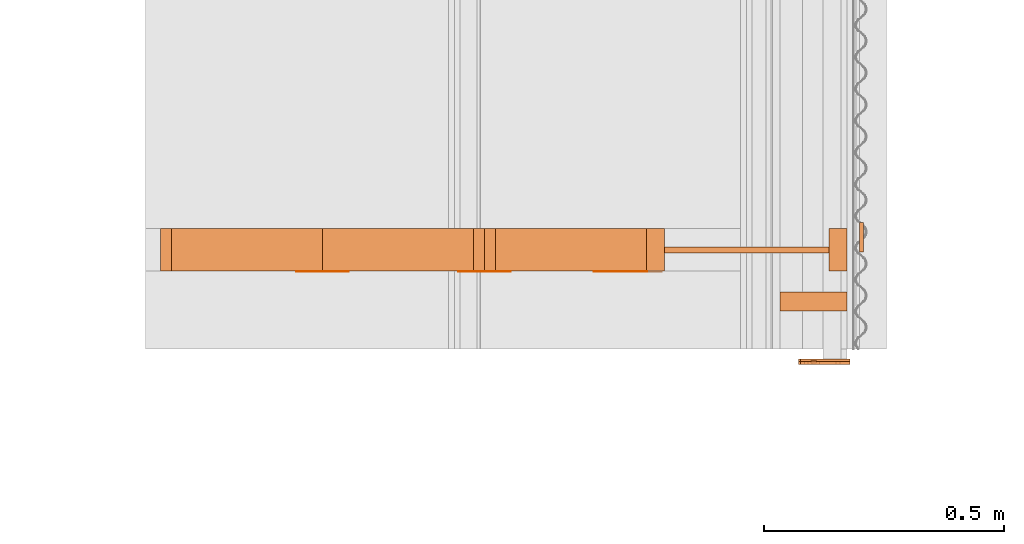
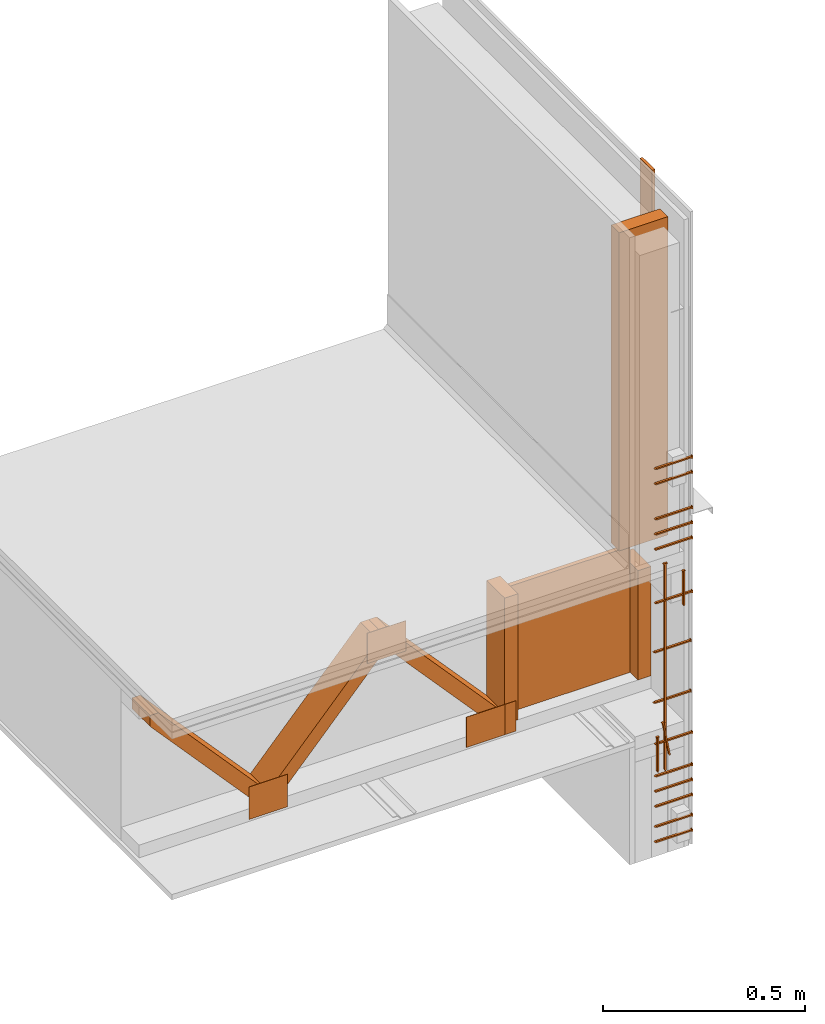
# One storey, part 8 of 22: 30 proxies.
"""IFC2X3 building model written with IfcOpenShell, lengths in feet."""

from ifc_helpers import new_model, entity, si_unit, converted_unit, frame, frame_2d, origin, origin_with_axes, place, context, subcontext, project, spatial, polyline, rectangle, outline, extrude, source, transform, mapped, material_list, type_object, type_shapes, element, save


model = new_model("IFC2X3")

# Units and contexts
model_context = context("Model", 3, precision=1e-05)
plan_context = context("Plan", 2, precision=1e-05, world=frame_2d((0.0, 0.0, 0.0), x_axis=(1.0, 0.0, 0.0)))
body_context_1 = subcontext(model_context, "Body", "Model", "MODEL_VIEW")
body_context_2 = subcontext(model_context, "Body", "Model", "MODEL_VIEW")
ifc_project = project(units=[converted_unit("VOLUMEUNIT", "cubic foot", entity("IfcReal", 0.0283168467116885), si_unit("VOLUMEUNIT", "CUBIC_METRE"), dimensions=[3, 0, 0, 0, 0, 0, 0]), converted_unit("AREAUNIT", "square foot", entity("IfcReal", 0.09290304), si_unit("AREAUNIT", "SQUARE_METRE"), dimensions=[2, 0, 0, 0, 0, 0, 0]), converted_unit("LENGTHUNIT", "foot", entity("IfcReal", 0.3048), si_unit("LENGTHUNIT", "METRE"), dimensions=[1, 0, 0, 0, 0, 0, 0])], contexts=[model_context, plan_context])

# Site, building, storey
site_placement = place(None, origin_with_axes())
site = spatial("IfcSite", under=ifc_project, at=site_placement, CompositionType="ELEMENT")
building_placement = place(site_placement, origin_with_axes())
building = spatial("IfcBuilding", under=site, at=building_placement, Name="Building", CompositionType="ELEMENT")
storey_placement = place(building_placement, origin_with_axes())
storey = spatial("IfcBuildingStorey", under=building, at=storey_placement, Name="Storey", CompositionType="ELEMENT")

# Proxies
ifc_material_list = material_list([])
building_element_proxy_type_1 = type_object("IfcBuildingElementProxyType", PredefinedType="NOTDEFINED", material=ifc_material_list)
shared_shape_1 = source(origin(), body_context_2, "Body", "SweptSolid", [
    extrude(outline(polyline([(0.678254804742618, 1.52290372278406e-09), (0.678378687755955, -0.00916582897667262), (0.687544515204868, -0.00904193908841474), (0.687048983151518, 0.0276213836931963), (0.677883155702606, 0.0274974915132983), (0.678007038715943, 0.0183316625366256), (-1.35638592202519, -0.0091658358515932), (-1.37459359613303, -0.0185794453686617), (-1.35613815599852, -0.0274974976243388), (0.678254804742618, 1.52290372278406e-09)])), frame((-0.0100000249649694, 9.22385177861048e-08, -0.678192814347625), z_axis=(-1.0, 0.0, 3.5932856690124e-08), x_axis=(3.60397933718559e-08, -0.0135152153670788, 0.999908626079559)), (-4.43113208348223e-08, -9.72645874952605e-09, -0.999999940395355), 0.0199999997321789),
])
type_shapes(building_element_proxy_type_1, [shared_shape_1])
proxy_1_placement = place(storey_placement, frame((1595.73852859457, 1.80479852859117, -59.9519724608093), z_axis=(-1.62920699153801e-07, -4.37113776285969e-08, 1.0), x_axis=(7.54979012640433e-08, 1.0, 4.37113882867379e-08)))
element("IfcBuildingElementProxy", 1, at=proxy_1_placement, inside=storey, type_object=building_element_proxy_type_1, context=body_context_2, shape_type="MappedRepresentation", body=[
    mapped(shared_shape_1, transform((0.0, 0.0, 0.0), x_axis=(1.0, 0.0, 0.0), y_axis=(0.0, 1.0, 0.0), z_axis=(0.0, 0.0, 1.0), scale=1.0)),
])
building_element_proxy_type_2 = type_object("IfcBuildingElementProxyType", PredefinedType="NOTDEFINED")
shared_shape_2 = source(origin_with_axes(), body_context_1, "Body", "SweptSolid", [
    extrude(outline(polyline([(0.111323627313291, 1.94594512519944e-12), (0.11174819796417, -0.00686187885598991), (0.11861007758404, -0.0064373005663101), (0.116911782758442, 0.0210102125660093), (0.110049903138572, 0.0205856342763295), (0.110474473789452, 0.0137237561842197), (-0.222222659531541, -0.00686187503658959), (-0.235521823676239, -0.0145729112358192), (-0.22137349378562, -0.0205856312208093), (0.111323627313291, 1.94594512519944e-12)])), frame((0.111111134212474, -9.54850080601499e-11, -8.48755740522435e-09), z_axis=(-7.22965936006403e-08, 7.6731799896184e-14, -1.0), x_axis=(-0.998091220855713, -0.0617568828165531, 7.2158591990501e-08)), (7.24534032769952e-08, -3.00251157270282e-10, -0.999999940395355), 0.0199999997321789),
])
type_shapes(building_element_proxy_type_2, [shared_shape_2])
for number, where, z_axis, x_axis in (
    (2, (1595.98082695107, 1.80479872414446, -60.8012745073774), (-3.25841369885893e-07, 1.0, 7.54979012640433e-08), (-1.0, -3.25841369885893e-07, -7.54979083694707e-08)),
    (3, (1595.98082695107, 1.80479852859117, -61.3012714335925), (-3.25841369885893e-07, 1.0, 7.54979012640433e-08), (-1.0, -3.25841369885893e-07, -7.54979083694707e-08)),
):
    element("IfcBuildingElementProxy", number, at=place(storey_placement, frame(where, z_axis=z_axis, x_axis=x_axis)), inside=storey, type_object=building_element_proxy_type_2, context=body_context_1, shape_type="MappedRepresentation", body=[
        mapped(shared_shape_2, transform((0.0, 0.0, 0.0), x_axis=(1.0, 0.0, 0.0), y_axis=(0.0, 1.0, 0.0), z_axis=(0.0, 0.0, 1.0), scale=1.0)),
    ])
building_element_proxy_type_3 = type_object("IfcBuildingElementProxyType", PredefinedType="NOTDEFINED")
shared_shape_3 = source(origin_with_axes(), body_context_1, "Body", "SweptSolid", [
    extrude(outline(polyline([(0.111323627313291, -4.3989495809459e-10), (0.11174819796417, -0.00686187809210984), (0.11861007758404, -0.00643729980243003), (0.11691175831428, 0.0210102125660093), (0.110049890916491, 0.0205856327485694), (0.110474473789452, 0.0137237546564596), (-0.222222659531541, -0.00686187580046965), (-0.235521848120402, -0.0145729081802989), (-0.22137349378562, -0.0205856312208093), (0.111323627313291, -4.3989495809459e-10)])), frame((0.111111134212474, 9.54850080601499e-11, -0.0200000086804153), z_axis=(-5.63213937709861e-08, 0.0, -1.0), x_axis=(-0.998091220855713, -0.0617568753659725, 6.86179575382084e-08)), (-2.94874541451051e-10, 4.76513584146687e-09, -0.999999940395355), 0.0199999997321788),
])
type_shapes(building_element_proxy_type_3, [shared_shape_3])
proxy_2_placement = place(storey_placement, frame((1595.66183415611, 1.80479852859117, -61.6394691267039), z_axis=(-1.62920684942947e-07, 1.0, -1.23001694617955e-14), x_axis=(7.54979012640433e-08, 0.0, -1.0)))
element("IfcBuildingElementProxy", 4, at=proxy_2_placement, inside=storey, type_object=building_element_proxy_type_3, context=body_context_1, shape_type="MappedRepresentation", body=[
    mapped(shared_shape_3, transform((0.0, 0.0, 0.0), x_axis=(1.0, 0.0, 0.0), y_axis=(0.0, 1.0, 0.0), z_axis=(0.0, 0.0, 1.0), scale=1.0)),
])
building_element_proxy_type_4 = type_object("IfcBuildingElementProxyType", PredefinedType="NOTDEFINED")
shared_shape_4 = source(origin_with_axes(), body_context_1, "Body", "SweptSolid", [
    extrude(outline(polyline([(-0.111111109768312, -0.0068750000238575), (0.222222243980786, -0.0068750000238575), (0.23597223180642, -2.15302076254909e-09), (0.222222268424948, 0.0068750023154977), (-0.111111121990393, 0.00687499925997744), (-0.111111109768312, 0.013750000047715), (-0.11798611590321, 0.013750000047715), (-0.11798611590321, -0.013750000047715), (-0.111111121990393, -0.0137500015754751), (-0.111111109768312, -0.0068750000238575)])), frame((0.111111109768312, 0.0, -0.020000005624895), z_axis=(-6.61350867403598e-08, -6.13854399169472e-14, -1.0), x_axis=(1.0, -2.29163998888282e-09, -6.87492018869307e-08)), (2.04888596323435e-14, 6.14665585682399e-14, -0.999999940395355), 0.0199999997321788),
])
type_shapes(building_element_proxy_type_4, [shared_shape_4])
proxy_3_placement = place(storey_placement, frame((1595.71409851234, 1.80479852859117, -61.5144714595765), z_axis=(-4.33873275085261e-08, 1.0, -7.5904100782509e-09), x_axis=(0.173648342490196, 5.90425555668794e-11, -0.984807729721069)))
element("IfcBuildingElementProxy", 5, at=proxy_3_placement, inside=storey, type_object=building_element_proxy_type_4, context=body_context_1, shape_type="MappedRepresentation", body=[
    mapped(shared_shape_4, transform((0.0, 0.0, 0.0), x_axis=(1.0, 0.0, 0.0), y_axis=(0.0, 1.0, 0.0), z_axis=(0.0, 0.0, 1.0), scale=1.0)),
])
building_element_proxy_type_5 = type_object("IfcBuildingElementProxyType", Name="PANEL EDGE REF SHEAR WALL SCHEDULE", PredefinedType="NOTDEFINED")
shared_shape_5 = source(origin_with_axes(), body_context_1, "Body", "SweptSolid", [
    extrude(outline(polyline([(0.23597223180642, 8.8975154745995e-18), (0.222222268424948, 0.00687500460713789), (-0.111111121990393, 0.00687499849609737), (-0.111111109768312, 0.0137499985199549), (-0.11798611590321, 0.0137499985199549), (-0.11798611590321, -0.0137500015754751), (-0.111111121990393, -0.0137500031032353), (-0.111111109768312, -0.00687500078773757), (0.222222243980786, -0.00687499773221731), (0.23597223180642, 8.8975154745995e-18)])), frame((0.111111109768312, -9.54850080601499e-11, -0.020000005624895), z_axis=(-6.14719368741135e-08, 0.0, -1.0), x_axis=(1.0, 7.23704740579478e-09, -6.47432187861341e-08)), (1.93505896527689e-14, 1.35692355582075e-22, -0.999999940395355), 0.0199999997321788),
])
type_shapes(building_element_proxy_type_5, [shared_shape_5])
for number, where, z_axis, x_axis in (
    (6, (1595.98082695107, 1.80479852859117, -59.118790263579), (-3.89414367418794e-07, 1.0, -1.62920684942947e-07), (-1.0, -3.89414367418794e-07, -7.5497894158616e-08)),
    (7, (1595.98082695107, 1.80479852859117, -58.9687930630261), (-3.89414367418794e-07, 1.0, -1.62920684942947e-07), (-1.0, -3.89414367418794e-07, -7.5497894158616e-08)),
    (8, (1595.98082695107, 1.80479852859117, -61.6987921747323), (-3.89414367418794e-07, 1.0, -1.62920684942947e-07), (-1.0, -3.89414367418794e-07, -7.5497894158616e-08)),
    (9, (1595.98082695107, 1.80479852859117, -62.6687928447573), (-3.89414367418794e-07, 1.0, -1.62920684942947e-07), (-1.0, -3.89414367418794e-07, -7.5497894158616e-08)),
    (10, (1595.98082695107, 1.80479852859117, -62.5187956442044), (-3.89414367418794e-07, 1.0, -1.62920684942947e-07), (-1.0, -3.89414367418794e-07, -7.5497894158616e-08)),
):
    element("IfcBuildingElementProxy", number, at=place(storey_placement, frame(where, z_axis=z_axis, x_axis=x_axis)), inside=storey, type_object=building_element_proxy_type_5, context=body_context_1, shape_type="MappedRepresentation", body=[
        mapped(shared_shape_5, transform((0.0, 0.0, 0.0), x_axis=(1.0, 0.0, 0.0), y_axis=(0.0, 1.0, 0.0), z_axis=(0.0, 0.0, 1.0), scale=1.0)),
    ])
building_element_proxy_type_6 = type_object("IfcBuildingElementProxyType", PredefinedType="NOTDEFINED")
shared_shape_6 = source(origin_with_axes(), body_context_1, "Body", "SweptSolid", [
    extrude(outline(polyline([(0.23597223180642, 8.8975154745995e-18), (0.222222268424948, 0.00687500460713789), (-0.111111121990393, 0.00687499849609737), (-0.111111109768312, 0.0137499985199549), (-0.11798611590321, 0.0137499985199549), (-0.11798611590321, -0.0137500015754751), (-0.111111121990393, -0.0137500031032353), (-0.111111109768312, -0.00687500078773757), (0.222222243980786, -0.00687499773221731), (0.23597223180642, 8.8975154745995e-18)])), frame((0.111111109768312, -9.54850080601499e-11, -0.020000005624895), z_axis=(-6.14719368741135e-08, 0.0, -1.0), x_axis=(1.0, 7.23704740579478e-09, -6.47432187861341e-08)), (1.93505896527689e-14, 1.35692355582075e-22, -0.999999940395355), 0.0199999997321788),
])
type_shapes(building_element_proxy_type_6, [shared_shape_6])
proxy_4_placement = place(storey_placement, frame((1595.98082695107, 1.80479852859117, -60.3012775811623), z_axis=(-3.89414367418794e-07, 1.0, -1.62920684942947e-07), x_axis=(-1.0, -3.89414367418794e-07, -7.54978870531886e-08)))
element("IfcBuildingElementProxy", 11, at=proxy_4_placement, inside=storey, type_object=building_element_proxy_type_6, context=body_context_1, shape_type="MappedRepresentation", body=[
    mapped(shared_shape_6, transform((0.0, 0.0, 0.0), x_axis=(1.0, 0.0, 0.0), y_axis=(0.0, 1.0, 0.0), z_axis=(0.0, 0.0, 1.0), scale=1.0)),
])
building_element_proxy_type_7 = type_object("IfcBuildingElementProxyType", PredefinedType="NOTDEFINED")
shared_shape_7 = source(origin_with_axes(), body_context_1, "Body", "SweptSolid", [
    extrude(outline(polyline([(-0.222222268424948, -0.00687500078773757), (0.111111121990393, -0.00687500078773757), (0.111111109768312, -0.0137500015754751), (0.11798611590321, -0.0137500015754751), (0.11798611590321, 0.0137499985199549), (0.111111121990393, 0.013750000047715), (0.111111109768312, 0.00687499849609737), (-0.222222243980786, 0.00687500155161763), (-0.23597223180642, 4.23241967865452e-09), (-0.222222268424948, -0.00687500078773757)])), frame((0.111111109768312, 8.3654694792787e-11, -0.020000005624895), z_axis=(-6.03443481850263e-08, -6.13854466932108e-14, -1.0), x_axis=(-1.0, 1.14581997223695e-08, 5.95826392668641e-08)), (-1.82123196731943e-14, -6.14665585682399e-14, -0.999999940395355), 0.0199999997321788),
])
type_shapes(building_element_proxy_type_7, [shared_shape_7])
for number, where, z_axis, x_axis in (
    (12, (1595.98082695107, 1.80479852859117, -59.7687843903469), (-3.89414367418794e-07, 1.0, -1.62920684942947e-07), (-1.0, -3.89414367418794e-07, -7.5497894158616e-08)),
    (13, (1595.98082695107, 1.80479852859117, -59.618787189794), (-3.89414367418794e-07, 1.0, -1.62920684942947e-07), (-1.0, -3.89414367418794e-07, -7.5497894158616e-08)),
    (14, (1595.98082695107, 1.80479852859117, -59.4687899892412), (-3.89414367418794e-07, 1.0, -1.62920684942947e-07), (-1.0, -3.89414367418794e-07, -7.5497894158616e-08)),
    (15, (1595.98082695107, 1.80479852859117, -62.3187868613896), (-3.89414367418794e-07, 1.0, -1.62920684942947e-07), (-1.0, -3.89414367418794e-07, -7.5497894158616e-08)),
    (16, (1595.98082695107, 1.80479852859117, -62.1687896608368), (-3.89414367418794e-07, 1.0, -1.62920684942947e-07), (-1.0, -3.89414367418794e-07, -7.5497894158616e-08)),
    (17, (1595.98082695107, 1.80479852859117, -62.0187924602839), (-3.89414367418794e-07, 1.0, -1.62920684942947e-07), (-1.0, -3.89414367418794e-07, -7.5497894158616e-08)),
):
    element("IfcBuildingElementProxy", number, at=place(storey_placement, frame(where, z_axis=z_axis, x_axis=x_axis)), inside=storey, type_object=building_element_proxy_type_7, context=body_context_1, shape_type="MappedRepresentation", body=[
        mapped(shared_shape_7, transform((0.0, 0.0, 0.0), x_axis=(1.0, 0.0, 0.0), y_axis=(0.0, 1.0, 0.0), z_axis=(0.0, 0.0, 1.0), scale=1.0)),
    ])
building_element_proxy_type_8 = type_object("IfcBuildingElementProxyType", Name="SUBFLOOR TO RIBBON BOARD", PredefinedType="NOTDEFINED")
shared_shape_8 = source(origin_with_axes(), body_context_1, "Body", "SweptSolid", [
    extrude(outline(polyline([(-0.222222268424948, -0.00687499849609737), (0.111111109768312, -0.00687499849609737), (0.111111109768312, -0.013750000047715), (0.117986103681129, -0.013750000047715), (0.117986103681129, 0.0137500031032353), (0.111111109768312, 0.0137500015754751), (0.111111109768312, 0.00687499925997744), (-0.222222243980786, 0.00687499925997744), (-0.23597223180642, -3.87233552310243e-09), (-0.222222268424948, -0.00687499849609737)])), frame((0.111111109768312, 1.11521265392398e-09, -0.020000005624895), z_axis=(-7.04017537600521e-08, -6.90586436234882e-14, -1.0), x_axis=(-1.0, -6.87492018869307e-09, 6.87492018869307e-08)), (-1.70740496936196e-14, 3.81939351257188e-08, -1.0), 0.0200000007111508),
])
type_shapes(building_element_proxy_type_8, [shared_shape_8])
proxy_5_placement = place(storey_placement, frame((1595.90643534823, 1.80479833303787, -60.0745671690293), z_axis=(-1.62920684942947e-07, 1.0, -1.23001694617955e-14), x_axis=(7.54979012640433e-08, 0.0, -1.0)))
element("IfcBuildingElementProxy", 18, at=proxy_5_placement, inside=storey, type_object=building_element_proxy_type_8, context=body_context_1, shape_type="MappedRepresentation", body=[
    mapped(shared_shape_8, transform((0.0, 0.0, 0.0), x_axis=(1.0, 0.0, 0.0), y_axis=(0.0, 1.0, 0.0), z_axis=(0.0, 0.0, 1.0), scale=1.0)),
])
proxy_6_placement = place(storey_placement, frame((1595.22189242946, -0.783451722832177, -57.8829747798249), z_axis=(0.0, 0.0, 1.0), x_axis=(1.0, 0.0, 0.0)))
element("IfcBuildingElementProxy", 19, at=proxy_6_placement, inside=storey, Name="Plane", context=body_context_1, shape_type="SweptSolid", body=[
    extrude(rectangle(XDim=0.129999920355563, YDim=0.458287070881728, at=frame_2d((0.0, 0.0, 0.0))), frame((0.516643596133535, 2.99930689841744, -2.07206552110006), z_axis=(0.0, 0.0, -1.0), x_axis=(0.0, 1.0, 0.0)), (0.0, 0.0, -1.0), 3.1556764266711),
])
proxy_7_placement = place(storey_placement, frame((1596.05311596487, 4.62063145762666, -59.6164906118798), z_axis=(0.0, 0.0, 1.0), x_axis=(1.0, 0.0, 0.0)))
element("IfcBuildingElementProxy", 20, at=proxy_7_placement, inside=storey, Name="Plane", context=body_context_1, shape_type="SweptSolid", body=[
    extrude(rectangle(XDim=0.20000017706096, YDim=0.0259999838903791, at=frame_2d((0.0, 0.0, 0.0))), frame((0.0130391027045062, -1.96291666644139, -1.5644263720575e-06), z_axis=(0.0, 0.0, -1.0), x_axis=(0.0, 0.999999940395355, 0.0)), (0.0, 0.0, -0.999999940395355), 2.99999996554402),
])
proxy_8_placement = place(storey_placement, frame((1592.06991120586, 2.42488121423196, -61.9758708583401), z_axis=(0.0, 0.0, 1.0), x_axis=(1.0, 0.0, 0.0)))
element("IfcBuildingElementProxy", 21, at=proxy_8_placement, inside=storey, Name="Generic Models 855:Generic Models 1", context=body_context_1, shape_type="SweptSolid", body=[
    extrude(outline(polyline([(-0.784177421115515, -0.0648421487157426), (0.754565518750293, -0.0648422464923909), (0.835367211988905, 0.00826408231039373), (0.784177372227191, 0.0648422220482288), (-0.754565469861969, 0.0648421487157426), (-0.835367211988905, -0.00826398453374547), (-0.784177421115515, -0.0648421487157426)])), frame((0.859770405636685, 2.21605038198473e-07, 1.08333436522897), z_axis=(-5.63129143316132e-09, -1.0, -3.61698013762179e-08), x_axis=(-0.670913577079773, 3.05994660720899e-08, -0.741535544395447)), (3.05994909410856e-08, 2.00910239556151e-08, -1.0), 0.291666664589754),
])
for number, where, z_axis, x_axis, name in (
    (22, (1592.06991120586, 2.42488121423196, -61.9758708583401), (0.0, 0.0, 1.0), (1.0, 0.0, 0.0), "Generic Models 855:Generic Models 1"),
    (23, (1589.85258087398, 2.42488121423196, -61.9758708583401), (0.0, 0.0, 1.0), (1.0, 0.0, 0.0), "Generic Models 855:Generic Models 1"),
):
    element("IfcBuildingElementProxy", number, at=place(storey_placement, frame(where, z_axis=z_axis, x_axis=x_axis)), inside=storey, Name=name, context=body_context_1, shape_type="SweptSolid", body=[
        extrude(outline(polyline([(-0.784177225562218, -0.0648422709365529), (0.75456571430359, -0.0648423442690391), (0.835367309765553, 0.00826388675709722), (0.784177470003839, 0.0648420509390944), (-0.754565274308673, 0.0648421731599047), (-0.835367016435608, -0.00826420453120404), (-0.784177225562218, -0.0648422709365529)])), frame((1.96849052205173, 0.291666910638959, 1.08333377856908), z_axis=(0.0, 1.0, 0.0), x_axis=(-0.670913577079773, 0.0, 0.741535604000092)), (0.0, 1.67617116630936e-07, -1.0), 0.291666664589758),
    ])
proxy_9_placement = place(storey_placement, frame((1590.96124603992, 2.42488121423196, -61.8508731912127), z_axis=(0.0, 0.0, 1.0), x_axis=(1.0, 0.0, 0.0)))
element("IfcBuildingElementProxy", 24, at=proxy_9_placement, inside=storey, Name="Generic Models 855:Generic Models 1", context=body_context_1, shape_type="SweptSolid", body=[
    extrude(rectangle(XDim=0.124999233345449, YDim=0.291669311091376, at=frame_2d((0.0, 0.0, 0.0))), frame((3.69392433191535, 0.145834848636717, 0.333333109307477), z_axis=(-1.56443593368749e-06, 0.0, -1.0), x_axis=(0.999999940395355, 0.0, -1.56443593368749e-06)), (-7.30079079858115e-07, 0.0, -1.0), 1.25000238621637),
])
proxy_10_placement = place(storey_placement, frame((1592.21128528825, 2.42488121423196, -61.8508731912127), z_axis=(0.0, 0.0, 1.0), x_axis=(1.0, 0.0, 0.0)))
element("IfcBuildingElementProxy", 25, at=proxy_10_placement, inside=storey, Name="Generic Models 855:Generic Models 1", context=body_context_1, shape_type="SweptSolid", body=[
    extrude(rectangle(XDim=0.124999233345449, YDim=0.291669311091376, at=frame_2d((0.0, 0.0, 0.0))), frame((3.69392433191535, 0.145834848636717, 0.333333109307477), z_axis=(-1.56443593368749e-06, 0.0, -1.0), x_axis=(-0.999999940395355, 0.0, 1.56443593368749e-06)), (6.02304339736293e-07, 0.0, -0.999999940395355), 1.08399728678613),
])
proxy_11_placement = place(storey_placement, frame((1596.85830744546, 2.54988416129836, -59.5704714457194), z_axis=(0.0, 0.0, 1.0), x_axis=(-1.62920684942947e-07, 1.0, 0.0)))
element("IfcBuildingElementProxy", 26, at=proxy_11_placement, inside=storey, Name="Plane", context=body_context_1, shape_type="SweptSolid", body=[
    extrude(rectangle(XDim=0.0416666640300221, YDim=1.12508459659183, at=frame_2d((0.0, 0.0, 0.0))), frame((0.0208332826654742, 1.57809906744269, -1.94706785397267), z_axis=(0.0, 0.0, -1.0), x_axis=(1.0, 0.0, 0.0)), (-1.46664405065167e-08, 0.0, -0.999999940395355), 1.25000482420942),
])
proxy_12_placement = place(storey_placement, frame((1592.11857112374, 2.42211120178693, -61.6217035008228), z_axis=(0.0, 0.0, 1.0), x_axis=(1.0, 0.0, 0.0)))
element("IfcBuildingElementProxy", 27, at=proxy_12_placement, inside=storey, Name="Generic Models 852:Generic Models 1", context=body_context_1, shape_type="SweptSolid", body=[
    extrude(rectangle(XDim=0.360929982303518, YDim=0.00277022707595213, at=frame_2d((0.0, 0.0, 0.0))), frame((2.39778886942726, 0.00138511354766121, 0.0), z_axis=(0.0, 0.0, -1.0), x_axis=(1.0, 0.0, 0.0)), (0.0, 0.0, -1.0), 0.301264184929359),
])
proxy_13_placement = place(storey_placement, frame((1592.19496519234, 2.42211120178693, -61.9550389567698), z_axis=(0.0, 0.0, 1.0), x_axis=(1.0, 0.0, 0.0)))
element("IfcBuildingElementProxy", 28, at=proxy_13_placement, inside=storey, Name="Generic Models 852:Generic Models 1", context=body_context_1, shape_type="SweptSolid", body=[
    extrude(rectangle(XDim=0.360930176725411, YDim=0.00277022707595213, at=frame_2d((0.0, 0.0, 0.0))), frame((1.28912702789457, 0.00138511354766121, 1.4904025071875), z_axis=(0.0, 0.0, -1.0), x_axis=(1.0, 0.0, 0.0)), (0.0, 0.0, -1.0), 0.301264218204712),
])
proxy_14_placement = place(storey_placement, frame((1592.19496519234, 2.42211120178693, -61.6217035008228), z_axis=(0.0, 0.0, 1.0), x_axis=(1.0, 0.0, 0.0)))
element("IfcBuildingElementProxy", 29, at=proxy_14_placement, inside=storey, Name="Generic Models 852:Generic Models 1", context=body_context_1, shape_type="SweptSolid", body=[
    extrude(rectangle(XDim=0.360930148950862, YDim=0.00277022707595213, at=frame_2d((0.0, 0.0, 0.0))), frame((0.180465076363149, 0.00138511354766121, 0.0), z_axis=(0.0, 0.0, -1.0), x_axis=(-1.0, 0.0, 0.0)), (0.0, 0.0, -1.0), 0.322097519461289),
])
proxy_15_placement = place(storey_placement, frame((1592.0145430277, 2.42211120178693, -61.6217035008228), z_axis=(0.0, 0.0, 1.0), x_axis=(1.0, 0.0, 0.0)))
element("IfcBuildingElementProxy", 30, at=proxy_15_placement, inside=storey, Name="Generic Models 852:Generic Models 1", context=body_context_1, shape_type="SweptSolid", body=[
    extrude(rectangle(XDim=0.360929982303518, YDim=0.00277022707595213, at=frame_2d((0.0, 0.0, 0.0))), frame((2.39778886942726, 0.00138511354766121, 0.0), z_axis=(0.0, 0.0, -1.0), x_axis=(1.0, 0.0, 0.0)), (0.0, 0.0, -1.0), 0.301264184929359),
])

save(model, "model.ifc")
